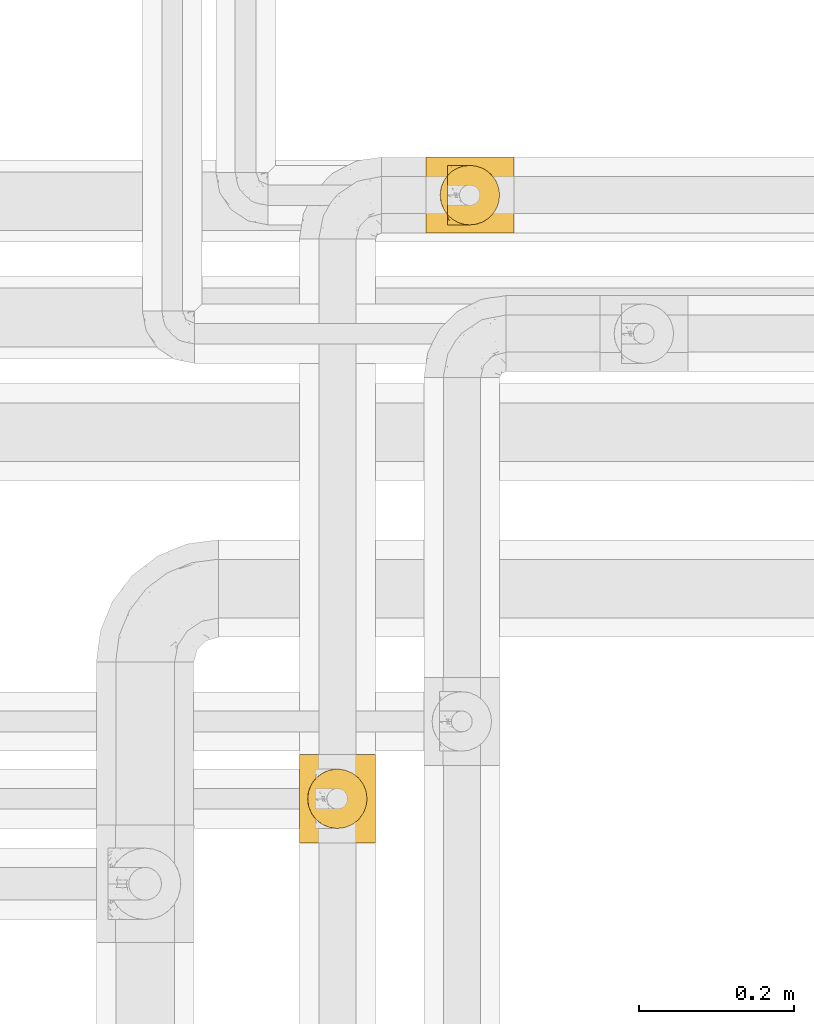
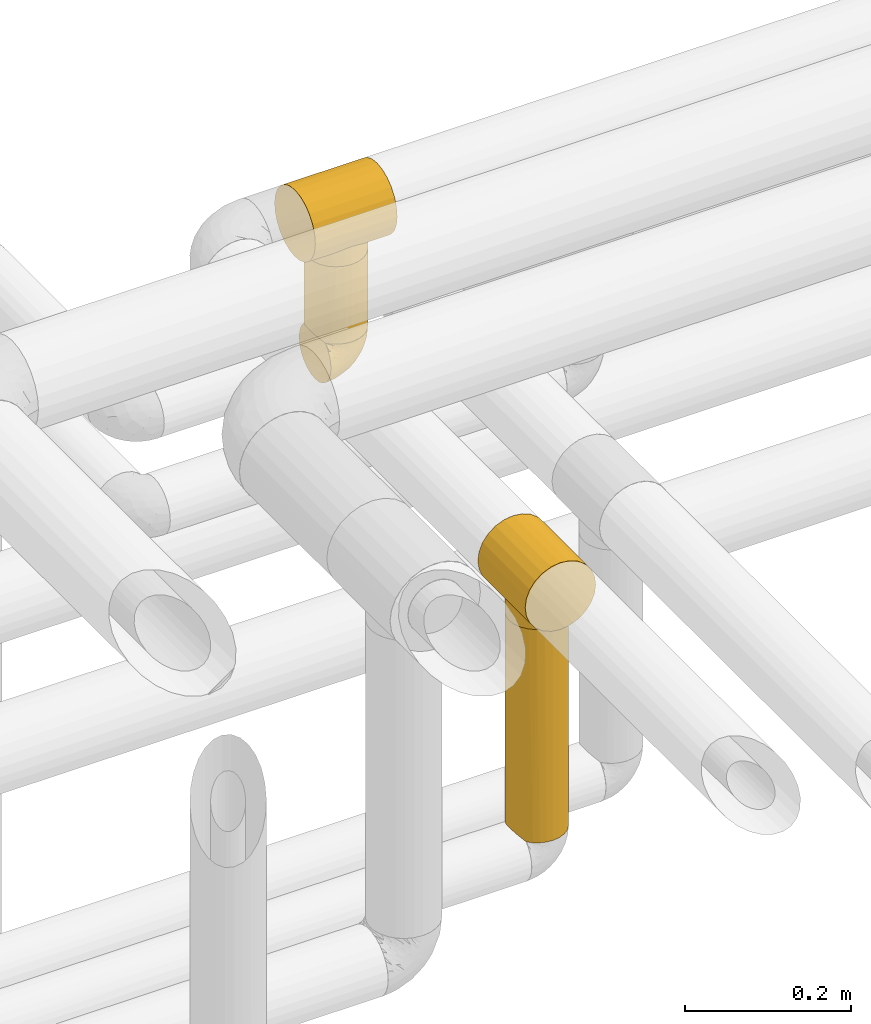
# One storey, part 362 of 827: 5 coverings.
"""IFC2X3 building model written with IfcOpenShell, lengths in millimetres."""

import ifcopenshell
import ifcopenshell.guid

model = None  # the IFC model being written
_history = None  # IfcOwnerHistory: only IFC2X3 demands one
_inside = {}  # id of a spatial element -> (the spatial element, [elements in it])
_under = {}  # id of a project, library or spatial element -> (it, [spatial elements below it])
_declared = {}  # id of a project -> (the project, [libraries it declares])
_typed = {}  # id of a type object -> (the type object, [elements of that type])
_made_of = {}  # id of a material, layer set ... -> (it, [elements and type objects made of it])


def new_model(schema):
    """Start an empty IFC model of exactly this schema.

    Asked for "IFC4X3", IfcOpenShell would pick the latest addendum, in which some entities
    have other attributes; the version numbers below select the first issue.
    IFC2X3 requires an IfcOwnerHistory on every rooted entity: one is made here for all.
    """
    global model, _history
    if schema == "IFC4X3":
        model = ifcopenshell.file(schema_version=(4, 3, 0, 0))
    else:
        model = ifcopenshell.file(schema=schema)
    _inside.clear()
    _under.clear()
    _declared.clear()
    _typed.clear()
    _made_of.clear()
    _history = None
    if model.schema == "IFC2X3":
        org = make("IfcOrganization", Name="unknown")
        user = make(
            "IfcPersonAndOrganization",
            ThePerson=make("IfcPerson", FamilyName="unknown"),
            TheOrganization=org,
        )
        app = make(
            "IfcApplication",
            ApplicationDeveloper=org,
            Version="unknown",
            ApplicationFullName="unknown",
            ApplicationIdentifier="unknown",
        )
        _history = make(
            "IfcOwnerHistory",
            OwningUser=user,
            OwningApplication=app,
            ChangeAction="ADDED",
            CreationDate=0,
        )
    return model


def make(cls, **values):
    """One entity of the class cls with the attributes given. An attribute that is None is left unset."""
    return model.create_entity(
        cls, **{name: value for name, value in values.items() if value is not None}
    )


def entity(cls, *values):
    """Any entity or typed value of the class cls, its attributes in the order of the schema. None: left unset."""
    e = model.create_entity(cls)
    for i, value in enumerate(values):
        if value is not None:
            e[i] = value
    return e


def rooted(cls, **values):
    """An entity with a GlobalId (a new one), such as an element, a storey or a relation."""
    return make(cls, GlobalId=ifcopenshell.guid.new(), OwnerHistory=_history, **values)


def si_unit(unit_type, name, prefix=None):
    """IfcSIUnit, for example si_unit("LENGTHUNIT", "METRE", prefix="MILLI")."""
    return make("IfcSIUnit", UnitType=unit_type, Prefix=prefix, Name=name)


def converted_unit(unit_type, name, factor, base, dimensions=None, offset=None):
    """IfcConversionBasedUnit, such as the inch: factor (a typed value) times the base unit."""
    return make(
        "IfcConversionBasedUnit"
        if offset is None
        else "IfcConversionBasedUnitWithOffset",
        ConversionOffset=offset,
        Dimensions=None
        if dimensions is None
        else entity("IfcDimensionalExponents", *dimensions),
        UnitType=unit_type,
        Name=name,
        ConversionFactor=make(
            "IfcMeasureWithUnit", ValueComponent=factor, UnitComponent=base
        ),
    )


def derived_unit(unit_type, elements):
    """IfcDerivedUnit: a product of units, each with its exponent."""
    return make(
        "IfcDerivedUnit",
        Elements=[
            make("IfcDerivedUnitElement", Unit=unit, Exponent=power)
            for unit, power in elements
        ],
        UnitType=unit_type,
    )


def assignment(units):
    """IfcUnitAssignment: the units of a project."""
    return None if units is None else make("IfcUnitAssignment", Units=units)


def point(xyz):
    """IfcCartesianPoint."""
    return None if xyz is None else make("IfcCartesianPoint", Coordinates=xyz)


def direction(xyz):
    """IfcDirection."""
    return None if xyz is None else make("IfcDirection", DirectionRatios=xyz)


def frame(location, z_axis=None, x_axis=None):
    """IfcAxis2Placement3D, a coordinate frame: its origin and axes. An axis left out is left unset."""
    return make(
        "IfcAxis2Placement3D",
        Location=point(location),
        Axis=direction(z_axis),
        RefDirection=direction(x_axis),
    )


def origin():
    """The frame at (0, 0, 0) with its axes left unset."""
    return frame((0.0, 0.0, 0.0))


def place(relative_to, where):
    """IfcLocalPlacement: puts the frame where relative to a parent placement (None: the world)."""
    return make(
        "IfcLocalPlacement", PlacementRelTo=relative_to, RelativePlacement=where
    )


def context(
    kind, dimensions, precision=None, world=None, true_north=None, identifier=None
):
    """IfcGeometricRepresentationContext, for example the 3D "Model" context."""
    return make(
        "IfcGeometricRepresentationContext",
        ContextIdentifier=identifier,
        ContextType=kind,
        CoordinateSpaceDimension=dimensions,
        Precision=precision,
        WorldCoordinateSystem=world,
        TrueNorth=true_north,
    )


def subcontext(parent, identifier, kind, view, scale=None):
    """IfcGeometricRepresentationSubContext, for example "Body" below "Model"."""
    return make(
        "IfcGeometricRepresentationSubContext",
        ContextIdentifier=identifier,
        ContextType=kind,
        ParentContext=parent,
        TargetScale=scale,
        TargetView=view,
    )


def project(units=None, contexts=None):
    """IfcProject with its units and contexts."""
    return rooted(
        "IfcProject",
        Name="project",
        RepresentationContexts=contexts,
        UnitsInContext=assignment(units),
    )


def spatial(cls, under=None, at=None, **own):
    """A site, building, storey or space (cls), placed at a placement, below another one or the project."""
    s = rooted(cls, ObjectPlacement=at, **own)
    if under is not None:
        _under.setdefault(under.id(), (under, []))[1].append(s)
    return s


def faces_of(points, faces, orient=None, outer=None):
    """IfcFace entities. A face is a list of loops; a loop is a list of indices into points, from 0.

    orient and outer hold one flag for each loop. By default every Orientation is true, the
    first loop of a face is its IfcFaceOuterBound and the others are IfcFaceBound.
    """
    made = []
    for i, loops in enumerate(faces):
        bounds = []
        for j, loop in enumerate(loops):
            is_outer = j == 0 if outer is None else outer[i][j]
            bounds.append(
                make(
                    "IfcFaceOuterBound" if is_outer else "IfcFaceBound",
                    Bound=make("IfcPolyLoop", Polygon=[points[k] for k in loop]),
                    Orientation=True if orient is None else orient[i][j],
                )
            )
        made.append(make("IfcFace", Bounds=bounds))
    return made


def faceted_brep(points, faces, orient=None, outer=None, voids=None):
    """IfcFacetedBrep: a solid bounded by flat faces; with voids (closed shells), ...WithVoids."""
    shared = [point(p) for p in points]
    hull = make("IfcClosedShell", CfsFaces=faces_of(shared, faces, orient, outer))
    if voids is None:
        return make("IfcFacetedBrep", Outer=hull)
    return make(
        "IfcFacetedBrepWithVoids",
        Outer=hull,
        Voids=[
            make(cls, CfsFaces=faces_of(shared, fs, o, b)) for cls, fs, o, b in voids
        ],
    )


def shape(context_of_items, identifier, shape_type, items):
    """IfcShapeRepresentation: the items that make up one representation, for example the "Body"."""
    return make(
        "IfcShapeRepresentation",
        ContextOfItems=context_of_items,
        RepresentationIdentifier=identifier,
        RepresentationType=shape_type,
        Items=items,
    )


def made_of(thing, what):
    """Note that an element or type object is made of a material, layer set ...; save() writes the relation."""
    if what is not None:
        _made_of.setdefault(what.id(), (what, []))[1].append(thing)
    return thing


def element(
    cls,
    number,
    at=None,
    inside=None,
    cuts=None,
    type_object=None,
    material=None,
    context=None,
    identifier="Body",
    shape_type=None,
    held_by="IfcProductDefinitionShape",
    body=None,
    shapes=None,
    **own,
):
    """One element of the class cls, such as IfcWall. Its Tag is "e" and its number.

    at: its placement. inside: the storey or other place that contains it. cuts: it is an
    opening in that element (IfcRelVoidsElement). A single representation is given by context,
    identifier, shape_type and body (its items); several are given by shapes. held_by: the class
    of the entity that holds the representations. save() writes the other relations.
    """
    e = rooted(cls, Tag="e%d" % number, ObjectPlacement=at, **own)
    if body is not None:
        shapes = [shape(context, identifier, shape_type, body)]
    if shapes is not None:
        e.Representation = make(held_by, Representations=shapes)
    if inside is not None:
        _inside.setdefault(inside.id(), (inside, []))[1].append(e)
    if cuts is not None:
        rooted(
            "IfcRelVoidsElement", RelatingBuildingElement=cuts, RelatedOpeningElement=e
        )
    if type_object is not None:
        _typed.setdefault(type_object.id(), (type_object, []))[1].append(e)
    return made_of(e, material)


def aggregate(whole, parts):
    """IfcRelAggregates: a whole, such as a stair, and the parts it consists of."""
    return rooted("IfcRelAggregates", RelatingObject=whole, RelatedObjects=parts)


def save(model, path):
    """Write the relations noted so far, then the file.

    IfcRelAggregates (storeys below a building ...), IfcRelContainedInSpatialStructure (elements
    in a storey), IfcRelDefinesByType, IfcRelAssociatesMaterial and IfcRelDeclares: one each for
    every whole, place, type object, material and project.
    """
    for whole, parts in _under.values():
        aggregate(whole, parts)
    for where, things in _inside.values():
        rooted(
            "IfcRelContainedInSpatialStructure",
            RelatedElements=things,
            RelatingStructure=where,
        )
    for kind, things in _typed.values():
        rooted("IfcRelDefinesByType", RelatedObjects=things, RelatingType=kind)
    for what, things in _made_of.values():
        rooted("IfcRelAssociatesMaterial", RelatedObjects=things, RelatingMaterial=what)
    for by, libraries in _declared.values():
        rooted("IfcRelDeclares", RelatingContext=by, RelatedDefinitions=libraries)
    model.write(path)


model = new_model("IFC2X3")

# Units and contexts
model_context = context("Model", 3, precision=0.01, world=origin(), true_north=direction((6.12303176911189e-17, 1.0)))
body_context = subcontext(model_context, "Body", "Model", "MODEL_VIEW")
ifc_project = project(units=[si_unit("LENGTHUNIT", "METRE", prefix="MILLI"), si_unit("AREAUNIT", "SQUARE_METRE"), si_unit("VOLUMEUNIT", "CUBIC_METRE"), converted_unit("PLANEANGLEUNIT", "DEGREE", entity("IfcRatioMeasure", 0.0174532925199433), si_unit("PLANEANGLEUNIT", "RADIAN"), dimensions=[0, 0, 0, 0, 0, 0, 0]), si_unit("MASSUNIT", "GRAM", prefix="KILO"), derived_unit("MASSDENSITYUNIT", [(si_unit("MASSUNIT", "GRAM", prefix="KILO"), 1), (si_unit("LENGTHUNIT", "METRE"), -3)]), derived_unit("MOMENTOFINERTIAUNIT", [(si_unit("LENGTHUNIT", "METRE"), 4)]), si_unit("TIMEUNIT", "SECOND"), si_unit("FREQUENCYUNIT", "HERTZ"), si_unit("THERMODYNAMICTEMPERATUREUNIT", "DEGREE_CELSIUS"), derived_unit("THERMALTRANSMITTANCEUNIT", [(si_unit("MASSUNIT", "GRAM", prefix="KILO"), 1), (si_unit("THERMODYNAMICTEMPERATUREUNIT", "KELVIN"), -1), (si_unit("TIMEUNIT", "SECOND"), -3)]), derived_unit("VOLUMETRICFLOWRATEUNIT", [(si_unit("LENGTHUNIT", "METRE"), 3), (si_unit("TIMEUNIT", "SECOND"), -1)]), derived_unit("MASSFLOWRATEUNIT", [(si_unit("MASSUNIT", "GRAM", prefix="KILO"), 1), (si_unit("TIMEUNIT", "SECOND"), -1)]), derived_unit("ROTATIONALFREQUENCYUNIT", [(si_unit("TIMEUNIT", "SECOND"), -1)]), si_unit("ELECTRICCURRENTUNIT", "AMPERE"), si_unit("ELECTRICVOLTAGEUNIT", "VOLT"), si_unit("POWERUNIT", "WATT"), si_unit("FORCEUNIT", "NEWTON", prefix="KILO"), si_unit("ILLUMINANCEUNIT", "LUX"), si_unit("LUMINOUSFLUXUNIT", "LUMEN"), si_unit("LUMINOUSINTENSITYUNIT", "CANDELA"), derived_unit("USERDEFINED", [(si_unit("MASSUNIT", "GRAM", prefix="KILO"), -1), (si_unit("LENGTHUNIT", "METRE"), -2), (si_unit("TIMEUNIT", "SECOND"), 3), (si_unit("LUMINOUSFLUXUNIT", "LUMEN"), 1)]), derived_unit("LINEARVELOCITYUNIT", [(si_unit("LENGTHUNIT", "METRE"), 1), (si_unit("TIMEUNIT", "SECOND"), -1)]), si_unit("PRESSUREUNIT", "PASCAL"), derived_unit("USERDEFINED", [(si_unit("LENGTHUNIT", "METRE"), -2), (si_unit("MASSUNIT", "GRAM", prefix="KILO"), 1), (si_unit("TIMEUNIT", "SECOND"), -2)]), derived_unit("LINEARFORCEUNIT", [(si_unit("MASSUNIT", "GRAM", prefix="KILO"), 1), (si_unit("LENGTHUNIT", "METRE"), 1), (si_unit("TIMEUNIT", "SECOND"), -2), (si_unit("LENGTHUNIT", "METRE"), -1)]), derived_unit("PLANARFORCEUNIT", [(si_unit("MASSUNIT", "GRAM", prefix="KILO"), 1), (si_unit("LENGTHUNIT", "METRE"), 1), (si_unit("TIMEUNIT", "SECOND"), -2), (si_unit("LENGTHUNIT", "METRE"), -2)])], contexts=[model_context])

# Site, building, storey
site_placement = place(None, origin())
site = spatial("IfcSite", under=ifc_project, at=site_placement, CompositionType="ELEMENT")
building_placement = place(site_placement, origin())
building = spatial("IfcBuilding", under=site, at=building_placement, CompositionType="ELEMENT")
storey_placement = place(building_placement, frame((0.0, 0.0, 28200.0)))
storey = spatial("IfcBuildingStorey", under=building, at=storey_placement, Name="08", CompositionType="ELEMENT", Elevation=28200.0)

# Coverings
covering_1_placement = place(storey_placement, frame((36600.03, 19075.49, 3227.5)))
element("IfcCovering", 1, at=covering_1_placement, inside=storey, Name=":ADSK_", ObjectType=":ADSK_", PredefinedType="INSULATION", context=body_context, shape_type="Brep", body=[
    faceted_brep([(77.09, 30.06, 115.39), (78.4, 40.0, 115.39), (77.09, 49.93, 115.39), (73.25, 59.2, 115.39), (67.15, 67.15, 115.39), (59.2, 73.25, 115.39), (49.93, 77.09, 115.39), (40.0, 78.4, 115.39), (30.06, 77.09, 115.39), (20.8, 73.25, 115.39), (12.84, 67.15, 115.39), (6.74, 59.2, 115.39), (2.9, 49.93, 115.39), (1.6, 40.0, 115.39), (2.9, 30.06, 115.39), (6.74, 20.8, 115.39), (12.84, 12.84, 115.39), (20.8, 6.74, 115.39), (30.06, 2.9, 115.39), (40.0, 1.6, 115.39), (49.93, 2.9, 115.39), (59.2, 6.74, 115.39), (67.15, 12.84, 115.39), (73.25, 20.8, 115.39), (78.4, 40.0, 1.6), (77.09, 30.06, 1.6), (73.25, 20.8, 1.6), (67.15, 12.84, 1.6), (59.2, 6.74, 1.6), (49.93, 2.9, 1.6), (40.0, 1.6, 1.6), (31.79, 2.48, 1.6), (23.98, 5.09, 1.6), (16.91, 9.31, 1.6), (10.9, 14.94, 1.6), (10.9, 65.05, 1.6), (16.91, 70.68, 1.6), (23.98, 74.9, 1.6), (31.79, 77.51, 1.6), (40.0, 78.4, 1.6), (49.93, 77.09, 1.6), (59.2, 73.25, 1.6), (67.15, 67.15, 1.6), (73.25, 59.2, 1.6), (77.09, 49.93, 1.6), (6.92, 59.51, 5.57), (4.0, 53.36, 8.5), (2.2, 46.78, 10.29), (1.6, 40.0, 10.9), (2.2, 33.21, 10.29), (4.0, 26.63, 8.5), (6.92, 20.48, 5.57)], [[[0, 1, 2, 3, 4, 5, 6, 7, 8, 9, 10, 11, 12, 13, 14, 15, 16, 17, 18, 19, 20, 21, 22, 23]], [[24, 25, 26, 27, 28, 29, 30, 31, 32, 33, 34, 35, 36, 37, 38, 39, 40, 41, 42, 43, 44]], [[29, 28, 21, 20]], [[30, 29, 20, 19]], [[28, 27, 22, 21]], [[0, 23, 26, 25]], [[1, 0, 25, 24]], [[27, 26, 23, 22]], [[2, 1, 24, 44]], [[3, 2, 44, 43]], [[43, 42, 4, 3]], [[6, 5, 41, 40]], [[7, 6, 40, 39]], [[42, 41, 5, 4]], [[7, 39, 38]], [[8, 38, 37]], [[9, 37, 36]], [[7, 38, 8]], [[8, 37, 9]], [[36, 10, 9]], [[36, 35, 10]], [[35, 45, 11]], [[46, 47, 12]], [[45, 46, 11]], [[11, 46, 12]], [[13, 12, 47]], [[48, 13, 47]], [[35, 11, 10]], [[49, 50, 14]], [[51, 34, 15]], [[50, 51, 15]], [[48, 49, 13]], [[13, 49, 14]], [[50, 15, 14]], [[34, 16, 15]], [[17, 33, 32]], [[18, 32, 31]], [[19, 31, 30]], [[16, 33, 17]], [[17, 32, 18]], [[31, 19, 18]], [[33, 16, 34]], [[49, 48, 47, 46, 45, 35, 34, 51, 50]]]),
])
covering_2_placement = place(storey_placement, frame((36583.02, 19064.74, 3342.89)))
element("IfcCovering", 2, at=covering_2_placement, inside=storey, Name=":ADSK_", ObjectType=":ADSK_", PredefinedType="INSULATION", context=body_context, shape_type="Brep", body=[
    faceted_brep([(114.0, 75.32, 99.57), (114.0, 63.47, 104.48), (114.0, 50.75, 106.15), (114.0, 38.02, 104.48), (114.0, 26.17, 99.57), (114.0, 15.99, 91.75), (114.0, 8.18, 81.58), (114.0, 3.27, 69.72), (114.0, 1.6, 57.0), (114.0, 3.27, 44.28), (114.0, 8.18, 32.43), (114.0, 15.99, 22.25), (114.0, 21.08, 18.34), (114.0, 26.17, 14.43), (114.0, 32.1, 11.98), (114.0, 38.02, 9.52), (114.0, 41.2, 9.11), (114.0, 44.38, 8.69), (114.0, 47.57, 8.27), (114.0, 50.75, 7.85), (114.0, 53.93, 8.27), (114.0, 57.11, 8.69), (114.0, 60.29, 9.11), (114.0, 63.47, 9.52), (114.0, 69.39, 11.98), (114.0, 75.32, 14.43), (114.0, 80.41, 18.34), (114.0, 85.5, 22.25), (114.0, 93.31, 32.43), (114.0, 98.22, 44.28), (114.0, 99.9, 57.0), (114.0, 98.22, 69.72), (114.0, 93.31, 81.58), (114.0, 85.5, 91.75), (0.0, 3.27, 69.72), (0.0, 8.18, 81.58), (0.0, 15.99, 91.75), (0.0, 26.17, 99.57), (0.0, 38.02, 104.48), (0.0, 50.75, 106.15), (0.0, 63.47, 104.48), (0.0, 75.32, 99.57), (0.0, 85.5, 91.75), (0.0, 93.31, 81.58), (0.0, 98.22, 69.72), (0.0, 99.9, 57.0), (0.0, 98.22, 44.28), (0.0, 93.31, 32.43), (0.0, 85.5, 22.25), (0.0, 80.41, 18.34), (0.0, 75.32, 14.43), (0.0, 69.39, 11.98), (0.0, 63.47, 9.52), (0.0, 60.29, 9.11), (0.0, 57.11, 8.69), (0.0, 53.93, 8.27), (0.0, 50.75, 7.85), (0.0, 47.57, 8.27), (0.0, 44.38, 8.69), (0.0, 41.2, 9.11), (0.0, 38.02, 9.52), (0.0, 32.1, 11.98), (0.0, 26.17, 14.43), (0.0, 21.08, 18.34), (0.0, 15.99, 22.25), (0.0, 8.18, 32.43), (0.0, 3.27, 44.28), (0.0, 1.6, 57.0), (33.09, 20.63, 18.16), (40.05, 16.23, 22.01), (27.23, 26.41, 14.3), (91.37, 33.5, 10.97), (48.08, 13.34, 25.11), (57.0, 12.3, 26.38), (65.92, 13.34, 25.11), (95.45, 50.75, 7.85), (18.55, 50.75, 7.85), (80.91, 20.63, 18.16), (73.95, 16.23, 22.01), (86.77, 26.41, 14.3), (22.63, 33.5, 10.97), (92.88, 37.63, 9.83), (19.61, 41.76, 8.68), (19.08, 46.25, 8.26), (21.12, 37.63, 9.83), (94.39, 41.76, 8.68), (94.92, 46.25, 8.26), (19.08, 55.24, 8.26), (21.12, 63.86, 9.83), (27.23, 75.08, 14.3), (19.61, 59.73, 8.68), (22.63, 67.99, 10.97), (92.88, 63.86, 9.83), (94.39, 59.73, 8.68), (94.92, 55.24, 8.26), (86.77, 75.08, 14.3), (91.37, 67.99, 10.97), (80.91, 80.86, 18.16), (33.09, 80.86, 18.16), (40.05, 85.26, 22.01), (48.08, 88.15, 25.11), (57.0, 89.2, 26.38), (73.95, 85.26, 22.01), (65.92, 88.15, 25.11), (57.0, 12.3, 0.0), (47.05, 13.61, 0.0), (37.77, 17.45, 0.0), (29.81, 23.56, 0.0), (23.7, 31.52, 0.0), (19.86, 40.79, 0.0), (18.55, 50.75, 0.0), (19.86, 60.7, 0.0), (23.7, 69.97, 0.0), (29.81, 77.93, 0.0), (37.77, 84.04, 0.0), (47.05, 87.89, 0.0), (57.0, 89.2, 0.0), (66.95, 87.89, 0.0), (76.22, 84.04, 0.0), (84.19, 77.93, 0.0), (90.3, 69.97, 0.0), (94.14, 60.7, 0.0), (95.45, 50.75, 0.0), (94.14, 40.79, 0.0), (90.3, 31.52, 0.0), (84.19, 23.56, 0.0), (76.22, 17.45, 0.0), (66.95, 13.61, 0.0)], [[[0, 1, 2, 3, 4, 5, 6, 7, 8, 9, 10, 11, 12, 13, 14, 15, 16, 17, 18, 19, 20, 21, 22, 23, 24, 25, 26, 27, 28, 29, 30, 31, 32, 33]], [[34, 35, 36, 37, 38, 39, 40, 41, 42, 43, 44, 45, 46, 47, 48, 49, 50, 51, 52, 53, 54, 55, 56, 57, 58, 59, 60, 61, 62, 63, 64, 65, 66, 67]], [[37, 36, 5, 4]], [[2, 39, 38, 3]], [[38, 37, 4, 3]], [[6, 35, 34, 7]], [[7, 34, 67, 8]], [[5, 36, 35, 6]], [[66, 9, 8, 67]], [[65, 10, 9, 66]], [[64, 68, 69]], [[63, 62, 70]], [[71, 15, 14]], [[69, 72, 64]], [[68, 64, 63]], [[64, 72, 65]], [[72, 73, 65]], [[74, 11, 10]], [[18, 75, 19]], [[76, 57, 56]], [[77, 11, 78]], [[78, 11, 74]], [[79, 12, 77]], [[74, 10, 73]], [[73, 10, 65]], [[70, 61, 80]], [[61, 70, 62]], [[80, 61, 60]], [[15, 71, 81]], [[82, 59, 58]], [[83, 57, 76]], [[84, 59, 82]], [[82, 58, 83]], [[83, 58, 57]], [[60, 84, 80]], [[17, 85, 86]], [[79, 13, 12]], [[59, 84, 60]], [[79, 14, 13]], [[14, 79, 71]], [[85, 17, 16]], [[77, 12, 11]], [[18, 17, 86]], [[15, 81, 16]], [[16, 81, 85]], [[75, 18, 86]], [[68, 63, 70]], [[54, 87, 55]], [[53, 52, 88]], [[76, 55, 87]], [[50, 89, 51]], [[54, 90, 87]], [[91, 51, 89]], [[91, 52, 51]], [[88, 90, 53]], [[92, 22, 93]], [[93, 21, 94]], [[75, 20, 19]], [[55, 76, 56]], [[20, 75, 94]], [[95, 25, 24]], [[90, 54, 53]], [[24, 23, 96]], [[95, 97, 26]], [[96, 23, 92]], [[89, 49, 98]], [[89, 50, 49]], [[94, 21, 20]], [[98, 48, 99]], [[48, 98, 49]], [[99, 48, 100]], [[52, 91, 88]], [[28, 47, 46, 29]], [[101, 100, 47]], [[47, 100, 48]], [[46, 45, 30, 29]], [[93, 22, 21]], [[102, 103, 27]], [[95, 24, 96]], [[26, 25, 95]], [[27, 97, 102]], [[103, 28, 27]], [[22, 92, 23]], [[101, 28, 103]], [[101, 47, 28]], [[97, 27, 26]], [[31, 44, 43, 32]], [[32, 43, 42, 33]], [[45, 44, 31, 30]], [[0, 41, 40, 1]], [[1, 40, 39, 2]], [[33, 42, 41, 0]], [[104, 105, 106, 107, 108, 109, 110, 111, 112, 113, 114, 115, 116, 117, 118, 119, 120, 121, 122, 123, 124, 125, 126, 127]], [[82, 110, 109]], [[80, 109, 108]], [[110, 82, 83, 76]], [[70, 80, 108]], [[109, 80, 84, 82]], [[108, 107, 70]], [[107, 106, 68]], [[106, 105, 69]], [[72, 105, 104]], [[68, 106, 69]], [[72, 69, 105]], [[73, 72, 104]], [[107, 68, 70]], [[74, 104, 127]], [[78, 127, 126]], [[73, 104, 74]], [[74, 127, 78]], [[126, 77, 78]], [[126, 125, 77]], [[79, 125, 124]], [[124, 123, 71]], [[122, 85, 123]], [[71, 79, 124]], [[122, 75, 86, 85]], [[123, 85, 81, 71]], [[125, 79, 77]], [[93, 122, 121]], [[96, 121, 120]], [[122, 93, 94, 75]], [[95, 96, 120]], [[121, 96, 92, 93]], [[120, 119, 95]], [[97, 119, 118]], [[118, 117, 102]], [[116, 103, 117]], [[97, 118, 102]], [[103, 102, 117]], [[101, 103, 116]], [[119, 97, 95]], [[100, 116, 115]], [[99, 115, 114]], [[101, 116, 100]], [[100, 115, 99]], [[114, 98, 99]], [[114, 113, 98]], [[89, 113, 112]], [[112, 111, 91]], [[110, 90, 111]], [[91, 89, 112]], [[110, 76, 87, 90]], [[111, 90, 88, 91]], [[113, 89, 98]]]),
])
covering_3_placement = place(storey_placement, frame((36609.33, 19075.44, 3159.95)))
element("IfcCovering", 3, at=covering_3_placement, inside=storey, Name=":ADSK_", ObjectType=":ADSK_", PredefinedType="INSULATION", context=body_context, shape_type="Brep", body=[
    faceted_brep([(47.38, 5.41, 69.15), (54.67, 9.99, 69.15), (60.76, 16.08, 69.15), (65.34, 23.37, 69.15), (68.18, 31.49, 69.15), (69.15, 40.05, 69.15), (68.18, 48.61, 69.15), (65.33, 56.73, 69.15), (60.75, 64.02, 69.15), (54.66, 70.11, 69.15), (47.37, 74.69, 69.15), (39.25, 77.53, 69.15), (30.7, 78.5, 69.15), (22.59, 77.63, 69.15), (14.86, 75.08, 69.15), (7.84, 70.97, 69.15), (1.85, 65.47, 69.15), (1.85, 63.27, 69.15), (1.85, 61.53, 69.15), (1.85, 59.57, 69.15), (1.85, 57.6, 69.15), (1.85, 55.63, 69.15), (1.85, 53.67, 69.15), (1.85, 51.7, 69.15), (1.85, 49.73, 69.15), (1.85, 47.54, 69.15), (1.85, 45.34, 69.15), (1.85, 43.15, 69.15), (1.85, 40.96, 69.15), (1.85, 38.76, 69.15), (1.85, 36.57, 69.15), (1.85, 34.37, 69.15), (1.85, 32.18, 69.15), (1.85, 29.98, 69.15), (1.85, 27.79, 69.15), (1.85, 25.6, 69.15), (1.85, 23.4, 69.15), (1.85, 21.21, 69.15), (1.85, 19.01, 69.15), (1.85, 16.82, 69.15), (1.85, 14.62, 69.15), (7.85, 9.12, 69.15), (14.88, 5.0, 69.15), (22.61, 2.46, 69.15), (30.7, 1.6, 69.15), (39.26, 2.56, 69.15), (1.6, 65.47, 68.89), (1.6, 70.97, 62.89), (1.6, 75.09, 55.87), (1.6, 77.63, 48.14), (1.6, 78.5, 40.05), (1.6, 77.19, 30.09), (1.6, 73.34, 20.82), (1.6, 67.23, 12.86), (1.6, 59.27, 6.75), (1.6, 50.0, 2.91), (1.6, 40.05, 1.6), (1.6, 30.09, 2.91), (1.6, 20.82, 6.75), (1.6, 12.86, 12.86), (1.6, 6.75, 20.82), (1.6, 2.91, 30.09), (1.6, 1.6, 40.05), (1.6, 2.46, 48.14), (1.6, 5.0, 55.87), (1.6, 9.12, 62.89), (1.6, 14.62, 68.89), (1.6, 16.82, 68.89), (1.6, 17.8, 68.89), (1.6, 19.39, 68.89), (1.6, 20.98, 68.89), (1.6, 22.57, 68.89), (1.6, 24.16, 68.89), (1.6, 25.75, 68.89), (1.6, 27.33, 68.89), (1.6, 28.92, 68.89), (1.6, 30.51, 68.89), (1.6, 32.1, 68.89), (1.6, 33.69, 68.89), (1.6, 35.28, 68.89), (1.6, 36.87, 68.89), (1.6, 38.46, 68.89), (1.6, 40.05, 68.89), (1.6, 41.63, 68.89), (1.6, 43.22, 68.89), (1.6, 44.81, 68.89), (1.6, 46.4, 68.89), (1.6, 47.99, 68.89), (1.6, 49.58, 68.89), (1.6, 51.17, 68.89), (1.6, 52.76, 68.89), (1.6, 54.72, 68.89), (1.6, 56.69, 68.89), (1.6, 58.88, 68.89), (1.6, 61.08, 68.89), (1.6, 63.27, 68.89), (1.78, 37.77, 68.97), (1.77, 36.07, 68.96), (1.78, 32.96, 68.97), (1.77, 31.36, 68.97), (1.79, 56.52, 68.98), (1.78, 54.96, 68.97), (1.76, 18.75, 68.96), (1.77, 58.07, 68.96), (1.77, 50.37, 68.96), (1.76, 23.36, 68.96), (1.77, 24.95, 68.96), (1.77, 42.43, 68.96), (1.8, 15.97, 69.0), (1.76, 51.96, 68.96), (1.77, 53.47, 68.96), (1.78, 48.63, 68.97), (1.77, 63.93, 68.96), (1.77, 40.93, 68.96), (1.76, 29.72, 68.96), (1.77, 62.4, 68.97), (1.78, 60.92, 68.97), (1.77, 17.31, 68.97), (1.77, 21.74, 68.96), (1.77, 34.56, 68.96), (1.78, 20.18, 68.97), (1.77, 14.62, 68.97), (1.8, 14.62, 69.02), (1.82, 14.62, 69.08), (1.77, 65.47, 68.97), (1.72, 65.47, 68.94), (1.66, 65.47, 68.92), (1.76, 59.5, 68.96), (1.77, 47.1, 68.96), (1.76, 45.61, 68.95), (1.77, 28.18, 68.96), (1.66, 14.62, 68.92), (1.72, 14.62, 68.94), (1.78, 26.61, 68.98), (1.82, 65.47, 69.08), (1.8, 65.47, 69.02), (1.77, 39.32, 68.96), (1.78, 44.12, 68.97), (3.72, 72.26, 61.33), (7.41, 76.57, 53.1), (6.13, 71.77, 63.33), (21.47, 78.5, 49.27), (19.34, 77.9, 55.53), (26.8, 78.5, 54.6), (8.87, 78.5, 41.99), (9.2, 75.52, 57.07), (12.79, 76.13, 57.95), (14.62, 77.81, 51.56), (7.34, 78.5, 41.58), (5.33, 72.4, 61.7), (17.64, 76.56, 63.33), (7.7, 71.77, 65.0), (9.41, 72.25, 67.02), (28.75, 78.5, 61.87), (16.15, 78.5, 43.94), (14.14, 75.75, 61.21), (29.16, 78.5, 63.4), (57.02, 50.46, 33.11), (64.92, 52.75, 52.82), (64.0, 40.05, 43.3), (11.92, 77.7, 33.73), (19.16, 77.66, 36.52), (28.65, 71.02, 24.87), (24.62, 63.45, 14.17), (15.19, 70.55, 18.43), (18.36, 75.57, 28.67), (9.2, 75.57, 26.0), (46.98, 72.61, 49.25), (50.24, 72.61, 59.72), (56.1, 67.24, 55.1), (28.97, 77.74, 44.72), (54.46, 57.43, 34.15), (21.34, 47.19, 5.25), (18.4, 54.76, 6.75), (66.44, 40.05, 55.54), (12.07, 63.45, 10.47), (45.49, 60.1, 25.49), (50.57, 63.72, 35.53), (36.04, 76.83, 48.22), (42.07, 76.34, 58.71), (62.12, 60.51, 57.42), (37.37, 72.59, 34.84), (29.39, 76.05, 36.87), (53.59, 66.15, 45.01), (58.06, 60.51, 44.4), (49.27, 51.88, 23.96), (29.63, 55.34, 11.2), (33.21, 48.67, 10.56), (40.1, 53.89, 16.81), (44.08, 46.73, 17.38), (49.36, 40.05, 21.38), (56.68, 40.05, 32.34), (15.2, 40.05, 4.3), (35.57, 63.95, 20.65), (41.7, 67.24, 29.66), (46.4, 69.62, 39.6), (41.41, 73.6, 42.55), (27.45, 40.05, 6.74), (38.4, 40.05, 14.06), (12.99, 4.52, 26.84), (21.33, 32.72, 5.28), (42.89, 27.18, 18.52), (57.04, 29.63, 33.13), (56.11, 12.86, 55.1), (62.13, 19.59, 57.43), (21.89, 9.54, 20.72), (16.62, 16.64, 11.46), (32.9, 17.48, 17.69), (46.99, 7.49, 49.26), (50.25, 7.49, 59.73), (42.08, 3.75, 58.71), (49.91, 20.75, 29.72), (15.6, 2.33, 35.35), (16.15, 1.6, 43.94), (8.87, 1.6, 41.99), (29.16, 1.6, 63.4), (13.16, 26.94, 4.93), (10.83, 9.54, 17.46), (33.8, 31.21, 10.94), (25.02, 25.33, 8.92), (64.92, 27.35, 52.83), (32.83, 8.17, 29.34), (20.56, 4.3, 30.26), (58.07, 19.59, 44.4), (21.46, 2.23, 39.06), (28.1, 2.45, 43.06), (26.8, 1.6, 54.6), (21.47, 1.6, 49.27), (51.29, 12.86, 42.69), (36.04, 3.27, 48.2), (28.75, 1.6, 61.87), (8.45, 2.29, 33.44), (41.73, 12.86, 29.67), (39.27, 6.89, 38.5), (33.56, 12.43, 23.35), (27.29, 4.1, 34.97), (7.41, 3.53, 53.1), (3.51, 6.88, 59.68), (4.68, 8.16, 62.19), (5.52, 9.02, 64.11), (8.75, 5.0, 57.97), (12.79, 3.96, 57.95), (17.65, 3.52, 63.33), (13.9, 2.4, 51.77), (9.42, 7.83, 67.02), (7.68, 8.32, 64.98), (19.33, 2.19, 55.53), (14.13, 4.34, 61.22)], [[[0, 1, 2, 3, 4, 5, 6, 7, 8, 9, 10, 11, 12, 13, 14, 15, 16, 17, 18, 19, 20, 21, 22, 23, 24, 25, 26, 27, 28, 29, 30, 31, 32, 33, 34, 35, 36, 37, 38, 39, 40, 41, 42, 43, 44, 45]], [[46, 47, 48, 49, 50, 51, 52, 53, 54, 55, 56, 57, 58, 59, 60, 61, 62, 63, 64, 65, 66, 67, 68, 69, 70, 71, 72, 73, 74, 75, 76, 77, 78, 79, 80, 81, 82, 83, 84, 85, 86, 87, 88, 89, 90, 91, 92, 93, 94, 95]], [[96, 97, 30]], [[98, 77, 99]], [[100, 101, 21]], [[69, 68, 102]], [[20, 19, 103]], [[24, 23, 104]], [[20, 103, 100]], [[72, 105, 106]], [[84, 83, 107]], [[89, 88, 104]], [[108, 67, 66]], [[109, 110, 90]], [[111, 25, 24]], [[112, 17, 16]], [[82, 113, 83]], [[109, 23, 22]], [[114, 76, 75]], [[105, 36, 106]], [[104, 111, 24]], [[18, 115, 116]], [[97, 96, 80]], [[67, 108, 117]], [[105, 71, 118]], [[31, 97, 119]], [[102, 120, 69]], [[108, 121, 122, 123, 40]], [[112, 95, 115]], [[17, 115, 18]], [[94, 116, 115]], [[117, 68, 67]], [[38, 117, 39]], [[112, 124, 125, 126, 46]], [[17, 112, 115]], [[70, 120, 118]], [[39, 117, 108]], [[120, 38, 37]], [[120, 37, 118]], [[120, 70, 69]], [[116, 94, 127]], [[128, 86, 129]], [[117, 38, 102]], [[74, 130, 75]], [[99, 33, 32]], [[115, 95, 94]], [[39, 108, 40]], [[108, 66, 131, 132, 121]], [[105, 72, 71]], [[118, 37, 36]], [[71, 70, 118]], [[35, 106, 36]], [[36, 105, 118]], [[35, 133, 106]], [[74, 73, 133]], [[106, 133, 73]], [[99, 114, 33]], [[133, 35, 34]], [[73, 72, 106]], [[95, 112, 46]], [[112, 16, 134, 135, 124]], [[130, 114, 75]], [[99, 76, 114]], [[114, 130, 33]], [[34, 33, 130]], [[78, 77, 98]], [[98, 119, 78]], [[130, 133, 34]], [[133, 130, 74]], [[79, 97, 80]], [[98, 99, 32]], [[98, 32, 31]], [[77, 76, 99]], [[97, 79, 119]], [[136, 96, 29]], [[30, 97, 31]], [[136, 29, 28]], [[81, 80, 96]], [[29, 96, 30]], [[31, 119, 98]], [[119, 79, 78]], [[96, 136, 81]], [[82, 81, 136]], [[113, 107, 83]], [[84, 107, 137]], [[107, 27, 137]], [[113, 28, 107]], [[27, 107, 28]], [[85, 84, 137]], [[137, 27, 26]], [[113, 136, 28]], [[136, 113, 82]], [[109, 89, 104]], [[86, 85, 129]], [[89, 109, 90]], [[111, 87, 128]], [[26, 129, 137]], [[88, 111, 104]], [[25, 111, 128]], [[22, 110, 109]], [[23, 109, 104]], [[110, 91, 90]], [[100, 92, 101]], [[110, 22, 101]], [[91, 110, 101]], [[116, 19, 18]], [[111, 88, 87]], [[127, 103, 19]], [[25, 128, 26]], [[86, 128, 87]], [[128, 129, 26]], [[137, 129, 85]], [[120, 102, 38]], [[117, 102, 68]], [[91, 101, 92]], [[21, 101, 22]], [[93, 92, 103]], [[100, 21, 20]], [[100, 103, 92]], [[127, 93, 103]], [[93, 127, 94]], [[116, 127, 19]], [[126, 138, 47]], [[48, 138, 139]], [[140, 125, 124]], [[141, 142, 143]], [[144, 49, 139]], [[145, 140, 146]], [[48, 139, 49]], [[139, 145, 147]], [[49, 144, 148, 50]], [[126, 125, 149]], [[14, 13, 150]], [[151, 146, 140]], [[149, 140, 145]], [[152, 151, 135]], [[152, 14, 150]], [[16, 15, 134]], [[13, 153, 150]], [[124, 151, 140]], [[141, 147, 142]], [[14, 152, 15]], [[15, 152, 134]], [[47, 46, 126]], [[139, 154, 144]], [[138, 48, 47]], [[125, 140, 149]], [[135, 134, 152]], [[146, 155, 142]], [[145, 146, 147]], [[149, 139, 138]], [[147, 141, 154]], [[147, 146, 142]], [[139, 147, 154]], [[139, 149, 145]], [[149, 138, 126]], [[155, 146, 151]], [[150, 143, 142]], [[152, 155, 151]], [[150, 142, 155]], [[13, 12, 156, 153]], [[153, 143, 150]], [[152, 150, 155]], [[151, 124, 135]], [[157, 158, 159]], [[160, 154, 161]], [[162, 163, 164]], [[165, 166, 160]], [[167, 168, 169]], [[141, 170, 161]], [[156, 12, 11]], [[158, 157, 171]], [[172, 55, 173]], [[158, 6, 174]], [[175, 54, 53]], [[52, 166, 164]], [[52, 164, 53]], [[54, 175, 173]], [[166, 52, 51]], [[176, 177, 171]], [[178, 143, 179]], [[156, 11, 179]], [[8, 7, 180]], [[169, 9, 8]], [[179, 143, 153, 156]], [[179, 11, 10]], [[168, 179, 10]], [[181, 162, 182]], [[179, 167, 178]], [[183, 184, 177]], [[183, 169, 184]], [[176, 171, 185]], [[172, 186, 187]], [[158, 7, 6]], [[159, 158, 174]], [[184, 180, 158]], [[54, 173, 55]], [[180, 169, 8]], [[188, 189, 187]], [[9, 168, 10]], [[186, 188, 187]], [[190, 157, 159, 191]], [[55, 172, 192]], [[176, 193, 194]], [[161, 170, 182]], [[162, 164, 165]], [[175, 164, 163]], [[51, 50, 148]], [[167, 195, 196]], [[178, 182, 170]], [[6, 5, 174]], [[158, 180, 7]], [[169, 180, 184]], [[169, 168, 9]], [[179, 168, 167]], [[182, 162, 165]], [[162, 194, 193]], [[161, 165, 160]], [[195, 181, 196]], [[192, 172, 197]], [[192, 56, 55]], [[189, 190, 198]], [[198, 197, 187]], [[172, 187, 197]], [[185, 189, 188]], [[198, 187, 189]], [[186, 172, 173]], [[173, 163, 186]], [[193, 186, 163]], [[176, 185, 188]], [[185, 157, 190]], [[188, 186, 193]], [[177, 176, 194]], [[188, 193, 176]], [[162, 193, 163]], [[195, 177, 194]], [[171, 177, 184]], [[181, 195, 194]], [[183, 167, 169]], [[162, 181, 194]], [[196, 182, 178]], [[158, 171, 184]], [[171, 157, 185]], [[177, 195, 183]], [[167, 183, 195]], [[182, 196, 181]], [[178, 170, 143]], [[178, 167, 196]], [[164, 175, 53]], [[173, 175, 163]], [[160, 51, 148]], [[164, 166, 165]], [[51, 160, 166]], [[160, 148, 144, 154]], [[141, 161, 154]], [[182, 165, 161]], [[190, 189, 185]], [[143, 170, 141]], [[60, 199, 61]], [[197, 200, 192]], [[201, 190, 202]], [[200, 57, 192]], [[203, 204, 2]], [[205, 206, 207]], [[208, 209, 210]], [[211, 207, 201]], [[212, 213, 214]], [[45, 215, 210]], [[216, 206, 58]], [[45, 44, 215]], [[59, 217, 60]], [[60, 217, 199]], [[0, 45, 210]], [[218, 201, 219]], [[202, 159, 220]], [[205, 221, 222]], [[223, 204, 203]], [[1, 203, 2]], [[57, 200, 216]], [[220, 3, 204]], [[220, 174, 4]], [[1, 0, 209]], [[212, 224, 213]], [[225, 226, 227]], [[228, 223, 203]], [[208, 210, 229]], [[210, 226, 229]], [[3, 220, 4]], [[58, 206, 59]], [[209, 203, 1]], [[202, 220, 223]], [[228, 203, 208]], [[202, 211, 201]], [[3, 2, 204]], [[202, 190, 191, 159]], [[210, 215, 230, 226]], [[199, 212, 231]], [[232, 233, 221]], [[233, 208, 229]], [[207, 206, 219]], [[217, 206, 205]], [[227, 224, 225]], [[233, 232, 228]], [[201, 207, 219]], [[234, 232, 221]], [[218, 219, 200]], [[202, 223, 211]], [[174, 220, 159]], [[174, 5, 4]], [[61, 231, 62]], [[220, 204, 223]], [[210, 209, 0]], [[203, 209, 208]], [[225, 233, 229]], [[224, 227, 213]], [[221, 233, 235]], [[57, 56, 192]], [[198, 218, 197]], [[200, 219, 216]], [[201, 198, 190]], [[197, 218, 200]], [[198, 201, 218]], [[206, 216, 219]], [[58, 57, 216]], [[231, 212, 214]], [[222, 212, 199]], [[228, 211, 223]], [[207, 211, 232]], [[62, 231, 214]], [[199, 231, 61]], [[233, 228, 208]], [[211, 228, 232]], [[222, 221, 235]], [[234, 205, 207]], [[206, 217, 59]], [[199, 217, 205]], [[205, 222, 199]], [[224, 222, 235]], [[222, 224, 212]], [[224, 235, 225]], [[233, 225, 235]], [[226, 225, 229]], [[205, 234, 221]], [[207, 232, 234]], [[63, 214, 236]], [[214, 213, 236]], [[214, 63, 62]], [[237, 236, 238]], [[238, 132, 131]], [[236, 237, 64]], [[239, 240, 241]], [[63, 236, 64]], [[131, 66, 65]], [[237, 131, 65]], [[242, 230, 43]], [[237, 65, 64]], [[239, 121, 132]], [[42, 242, 43]], [[241, 240, 243]], [[41, 123, 244]], [[43, 230, 215, 44]], [[244, 122, 245]], [[227, 246, 243]], [[241, 247, 245]], [[121, 239, 245]], [[41, 40, 123]], [[132, 238, 239]], [[244, 42, 41]], [[131, 237, 238]], [[240, 239, 238]], [[245, 239, 241]], [[247, 241, 246]], [[247, 244, 245]], [[238, 236, 240]], [[243, 236, 213]], [[236, 243, 240]], [[227, 226, 246]], [[243, 213, 227]], [[242, 246, 226]], [[243, 246, 241]], [[246, 242, 247]], [[244, 247, 242]], [[242, 226, 230]], [[42, 244, 242]], [[122, 244, 123]], [[122, 121, 245]]]),
])
covering_4_placement = place(storey_placement, frame((36428.72, 18294.92, 3027.67)))
element("IfcCovering", 4, at=covering_4_placement, inside=storey, Name=":ADSK_", ObjectType=":ADSK_", PredefinedType="INSULATION", context=body_context, shape_type="Brep", body=[
    faceted_brep([(77.09, 30.06, 315.22), (78.4, 40.0, 315.22), (77.09, 49.93, 315.22), (73.25, 59.2, 315.22), (67.15, 67.15, 315.22), (59.2, 73.25, 315.22), (49.93, 77.09, 315.22), (40.0, 78.4, 315.22), (30.06, 77.09, 315.22), (20.8, 73.25, 315.22), (12.84, 67.15, 315.22), (6.74, 59.2, 315.22), (2.9, 49.93, 315.22), (1.6, 40.0, 315.22), (2.9, 30.06, 315.22), (6.74, 20.8, 315.22), (12.84, 12.84, 315.22), (20.8, 6.74, 315.22), (30.06, 2.9, 315.22), (40.0, 1.6, 315.22), (49.93, 2.9, 315.22), (59.2, 6.74, 315.22), (67.15, 12.84, 315.22), (73.25, 20.8, 315.22), (78.4, 40.0, 1.6), (77.09, 30.06, 1.6), (73.25, 20.8, 1.6), (67.15, 12.84, 1.6), (59.2, 6.74, 1.6), (49.93, 2.9, 1.6), (40.0, 1.6, 1.6), (31.79, 2.48, 1.6), (23.98, 5.09, 1.6), (16.91, 9.31, 1.6), (10.9, 14.94, 1.6), (10.9, 65.05, 1.6), (16.91, 70.68, 1.6), (23.98, 74.9, 1.6), (31.79, 77.51, 1.6), (40.0, 78.4, 1.6), (49.93, 77.09, 1.6), (59.2, 73.25, 1.6), (67.15, 67.15, 1.6), (73.25, 59.2, 1.6), (77.09, 49.93, 1.6), (6.92, 59.51, 5.57), (4.0, 53.36, 8.5), (2.2, 46.78, 10.29), (1.6, 40.0, 10.9), (2.2, 33.21, 10.29), (4.0, 26.63, 8.5), (6.92, 20.48, 5.57)], [[[0, 1, 2, 3, 4, 5, 6, 7, 8, 9, 10, 11, 12, 13, 14, 15, 16, 17, 18, 19, 20, 21, 22, 23]], [[24, 25, 26, 27, 28, 29, 30, 31, 32, 33, 34, 35, 36, 37, 38, 39, 40, 41, 42, 43, 44]], [[29, 28, 21, 20]], [[30, 29, 20, 19]], [[22, 21, 28, 27]], [[0, 23, 26, 25]], [[1, 0, 25, 24]], [[27, 26, 23, 22]], [[2, 1, 24, 44]], [[3, 2, 44, 43]], [[43, 42, 4, 3]], [[6, 5, 41, 40]], [[7, 6, 40, 39]], [[42, 41, 5, 4]], [[7, 39, 38]], [[8, 38, 37]], [[9, 37, 36]], [[7, 38, 8]], [[8, 37, 9]], [[36, 10, 9]], [[36, 35, 10]], [[35, 45, 11]], [[46, 47, 12]], [[45, 46, 11]], [[11, 46, 12]], [[13, 12, 47]], [[48, 13, 47]], [[35, 11, 10]], [[49, 50, 14]], [[51, 34, 15]], [[50, 51, 15]], [[48, 49, 13]], [[13, 49, 14]], [[50, 15, 14]], [[34, 16, 15]], [[17, 33, 32]], [[18, 32, 31]], [[19, 31, 30]], [[16, 33, 17]], [[17, 32, 18]], [[31, 19, 18]], [[33, 16, 34]], [[47, 46, 45, 35, 34, 51, 50, 49, 48]]]),
])
covering_5_placement = place(storey_placement, frame((36417.97, 18277.91, 3342.89)))
element("IfcCovering", 5, at=covering_5_placement, inside=storey, Name=":ADSK_", ObjectType=":ADSK_", PredefinedType="INSULATION", context=body_context, shape_type="Brep", body=[
    faceted_brep([(26.17, 114.0, 99.57), (38.02, 114.0, 104.48), (50.75, 114.0, 106.15), (63.47, 114.0, 104.48), (75.32, 114.0, 99.57), (85.5, 114.0, 91.75), (93.31, 114.0, 81.58), (98.22, 114.0, 69.72), (99.9, 114.0, 57.0), (98.22, 114.0, 44.28), (93.31, 114.0, 32.43), (85.5, 114.0, 22.25), (80.41, 114.0, 18.34), (75.32, 114.0, 14.43), (69.39, 114.0, 11.98), (63.47, 114.0, 9.52), (60.29, 114.0, 9.11), (57.11, 114.0, 8.69), (53.93, 114.0, 8.27), (50.75, 114.0, 7.85), (47.57, 114.0, 8.27), (44.38, 114.0, 8.69), (41.2, 114.0, 9.11), (38.02, 114.0, 9.52), (32.1, 114.0, 11.98), (26.17, 114.0, 14.43), (21.08, 114.0, 18.34), (15.99, 114.0, 22.25), (8.18, 114.0, 32.43), (3.27, 114.0, 44.28), (1.6, 114.0, 57.0), (3.27, 114.0, 69.72), (8.18, 114.0, 81.58), (15.99, 114.0, 91.75), (98.22, 0.0, 69.72), (93.31, 0.0, 81.58), (85.5, 0.0, 91.75), (75.32, 0.0, 99.57), (63.47, 0.0, 104.48), (50.75, 0.0, 106.15), (38.02, 0.0, 104.48), (26.17, 0.0, 99.57), (15.99, 0.0, 91.75), (8.18, 0.0, 81.58), (3.27, 0.0, 69.72), (1.6, 0.0, 57.0), (3.27, 0.0, 44.28), (8.18, 0.0, 32.43), (15.99, 0.0, 22.25), (21.08, 0.0, 18.34), (26.17, 0.0, 14.43), (32.1, 0.0, 11.98), (38.02, 0.0, 9.52), (41.2, 0.0, 9.11), (44.38, 0.0, 8.69), (47.57, 0.0, 8.27), (50.75, 0.0, 7.85), (53.93, 0.0, 8.27), (57.11, 0.0, 8.69), (60.29, 0.0, 9.11), (63.47, 0.0, 9.52), (69.39, 0.0, 11.98), (75.32, 0.0, 14.43), (80.41, 0.0, 18.34), (85.5, 0.0, 22.25), (93.31, 0.0, 32.43), (98.22, 0.0, 44.28), (99.9, 0.0, 57.0), (80.86, 33.09, 18.16), (85.26, 40.05, 22.01), (75.08, 27.23, 14.3), (67.99, 91.37, 10.97), (88.15, 48.08, 25.11), (89.2, 57.0, 26.38), (88.15, 65.92, 25.11), (50.75, 95.45, 7.85), (50.75, 18.55, 7.85), (80.86, 80.91, 18.16), (85.26, 73.95, 22.01), (75.08, 86.77, 14.3), (67.99, 22.63, 10.97), (63.86, 92.88, 9.83), (59.73, 19.61, 8.68), (55.24, 19.08, 8.26), (63.86, 21.12, 9.83), (59.73, 94.39, 8.68), (55.24, 94.92, 8.26), (46.25, 19.08, 8.26), (37.63, 21.12, 9.83), (26.41, 27.23, 14.3), (41.76, 19.61, 8.68), (33.5, 22.63, 10.97), (37.63, 92.88, 9.83), (41.76, 94.39, 8.68), (46.25, 94.92, 8.26), (26.41, 86.77, 14.3), (33.5, 91.37, 10.97), (20.63, 80.91, 18.16), (20.63, 33.09, 18.16), (16.23, 40.05, 22.01), (13.34, 48.08, 25.11), (12.3, 57.0, 26.38), (16.23, 73.95, 22.01), (13.34, 65.92, 25.11), (89.2, 57.0, 0.0), (87.89, 47.05, 0.0), (84.04, 37.77, 0.0), (77.93, 29.81, 0.0), (69.97, 23.7, 0.0), (60.7, 19.86, 0.0), (50.75, 18.55, 0.0), (40.79, 19.86, 0.0), (31.52, 23.7, 0.0), (23.56, 29.81, 0.0), (17.45, 37.77, 0.0), (13.61, 47.05, 0.0), (12.3, 57.0, 0.0), (13.61, 66.95, 0.0), (17.45, 76.22, 0.0), (23.56, 84.19, 0.0), (31.52, 90.3, 0.0), (40.79, 94.14, 0.0), (50.75, 95.45, 0.0), (60.7, 94.14, 0.0), (69.97, 90.3, 0.0), (77.93, 84.19, 0.0), (84.04, 76.22, 0.0), (87.89, 66.95, 0.0)], [[[0, 1, 2, 3, 4, 5, 6, 7, 8, 9, 10, 11, 12, 13, 14, 15, 16, 17, 18, 19, 20, 21, 22, 23, 24, 25, 26, 27, 28, 29, 30, 31, 32, 33]], [[34, 35, 36, 37, 38, 39, 40, 41, 42, 43, 44, 45, 46, 47, 48, 49, 50, 51, 52, 53, 54, 55, 56, 57, 58, 59, 60, 61, 62, 63, 64, 65, 66, 67]], [[37, 36, 5, 4]], [[2, 39, 38, 3]], [[38, 37, 4, 3]], [[6, 35, 34, 7]], [[7, 34, 67, 8]], [[5, 36, 35, 6]], [[66, 9, 8, 67]], [[65, 10, 9, 66]], [[64, 68, 69]], [[63, 62, 70]], [[71, 15, 14]], [[69, 72, 64]], [[68, 64, 63]], [[64, 72, 65]], [[72, 73, 65]], [[74, 11, 10]], [[18, 75, 19]], [[76, 57, 56]], [[77, 11, 78]], [[78, 11, 74]], [[79, 12, 77]], [[74, 10, 73]], [[73, 10, 65]], [[70, 61, 80]], [[61, 70, 62]], [[80, 61, 60]], [[15, 71, 81]], [[82, 59, 58]], [[83, 57, 76]], [[84, 59, 82]], [[82, 58, 83]], [[83, 58, 57]], [[60, 84, 80]], [[17, 85, 86]], [[79, 13, 12]], [[59, 84, 60]], [[79, 14, 13]], [[14, 79, 71]], [[85, 17, 16]], [[77, 12, 11]], [[18, 17, 86]], [[15, 81, 16]], [[16, 81, 85]], [[75, 18, 86]], [[68, 63, 70]], [[54, 87, 55]], [[53, 52, 88]], [[76, 55, 87]], [[50, 89, 51]], [[54, 90, 87]], [[91, 51, 89]], [[91, 52, 51]], [[88, 90, 53]], [[92, 22, 93]], [[93, 21, 94]], [[75, 20, 19]], [[55, 76, 56]], [[20, 75, 94]], [[95, 25, 24]], [[90, 54, 53]], [[24, 23, 96]], [[95, 97, 26]], [[96, 23, 92]], [[89, 49, 98]], [[89, 50, 49]], [[94, 21, 20]], [[98, 48, 99]], [[48, 98, 49]], [[99, 48, 100]], [[52, 91, 88]], [[28, 47, 46, 29]], [[101, 100, 47]], [[47, 100, 48]], [[46, 45, 30, 29]], [[93, 22, 21]], [[102, 103, 27]], [[95, 24, 96]], [[26, 25, 95]], [[27, 97, 102]], [[103, 28, 27]], [[22, 92, 23]], [[101, 28, 103]], [[101, 47, 28]], [[97, 27, 26]], [[31, 44, 43, 32]], [[32, 43, 42, 33]], [[45, 44, 31, 30]], [[0, 41, 40, 1]], [[1, 40, 39, 2]], [[33, 42, 41, 0]], [[104, 105, 106, 107, 108, 109, 110, 111, 112, 113, 114, 115, 116, 117, 118, 119, 120, 121, 122, 123, 124, 125, 126, 127]], [[82, 110, 109]], [[80, 109, 108]], [[110, 82, 83, 76]], [[70, 80, 108]], [[109, 80, 84, 82]], [[108, 107, 70]], [[107, 106, 68]], [[106, 105, 69]], [[72, 105, 104]], [[68, 106, 69]], [[72, 69, 105]], [[73, 72, 104]], [[107, 68, 70]], [[74, 104, 127]], [[78, 127, 126]], [[73, 104, 74]], [[74, 127, 78]], [[126, 77, 78]], [[126, 125, 77]], [[79, 125, 124]], [[124, 123, 71]], [[122, 85, 123]], [[71, 79, 124]], [[122, 75, 86, 85]], [[123, 85, 81, 71]], [[125, 79, 77]], [[93, 122, 121]], [[96, 121, 120]], [[122, 93, 94, 75]], [[95, 96, 120]], [[121, 96, 92, 93]], [[120, 119, 95]], [[97, 119, 118]], [[118, 117, 102]], [[116, 103, 117]], [[97, 118, 102]], [[103, 102, 117]], [[101, 103, 116]], [[119, 97, 95]], [[100, 116, 115]], [[99, 115, 114]], [[101, 116, 100]], [[100, 115, 99]], [[114, 98, 99]], [[114, 113, 98]], [[89, 113, 112]], [[112, 111, 91]], [[110, 90, 111]], [[91, 89, 112]], [[110, 76, 87, 90]], [[111, 90, 88, 91]], [[113, 89, 98]]]),
])

save(model, "model.ifc")
